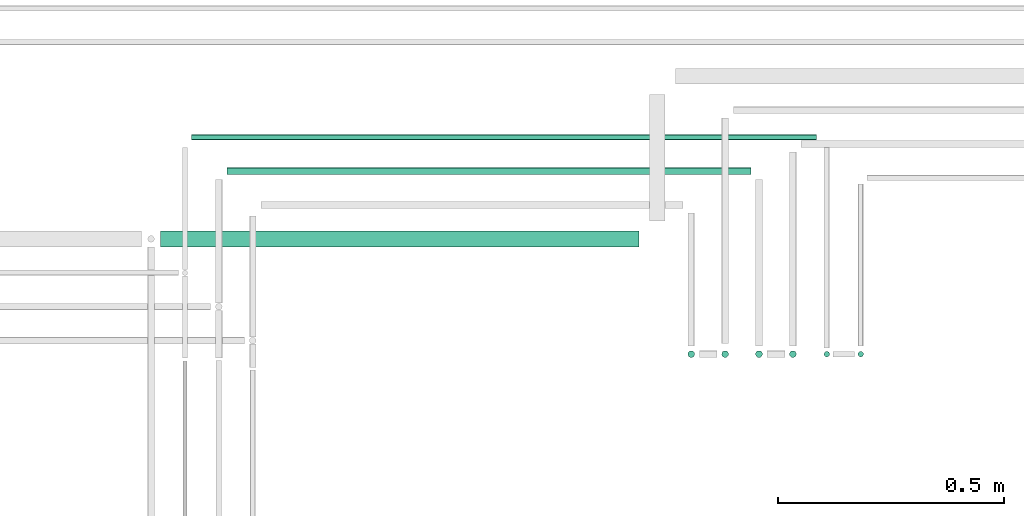
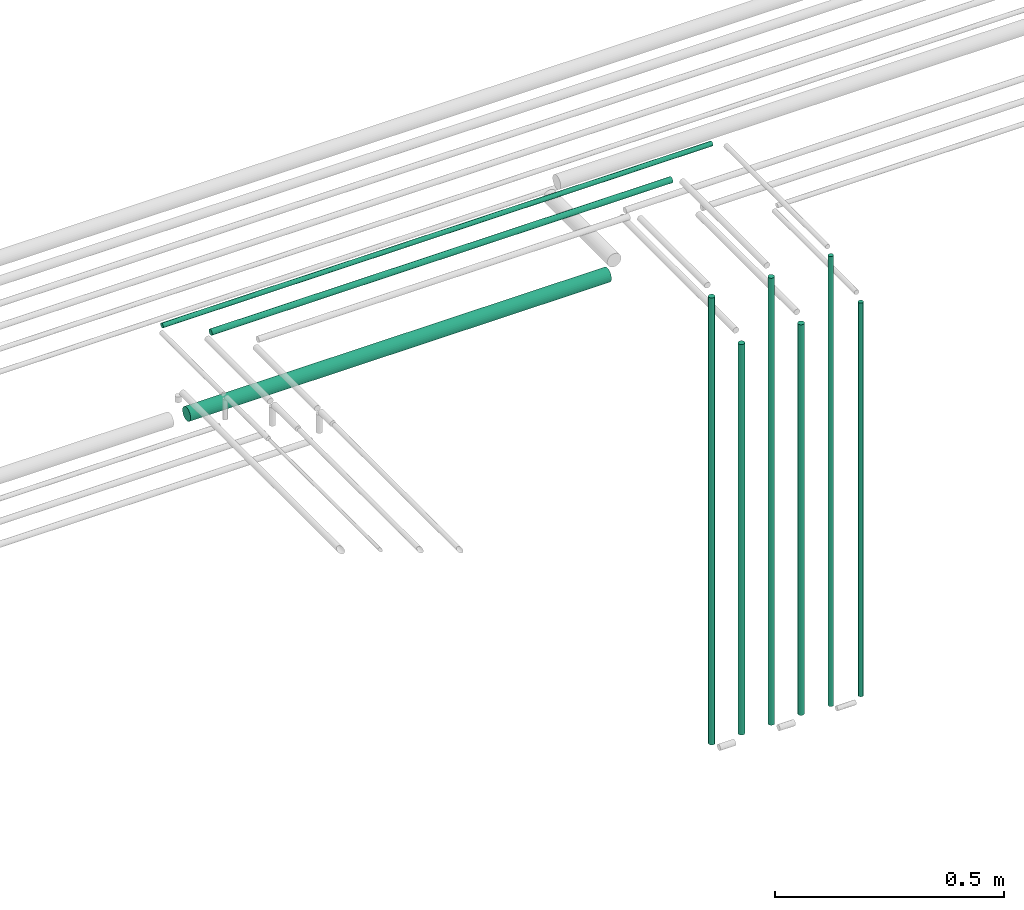
# One storey, part 16 of 65: 9 flow segments.
"""IFC2X3 building model written with IfcOpenShell, lengths in millimetres."""

from ifc_helpers import new_model, entity, si_unit, converted_unit, derived_unit, direction, frame, frame_2d, origin, origin_2d_with_axis, place, context, subcontext, project, spatial, circle, extrude, type_object, element, save


model = new_model("IFC2X3")

# Units and contexts
model_context = context("Model", 3, precision=0.01, world=origin(), true_north=direction((6.12303176911189e-17, 1.0)))
body_context = subcontext(model_context, "Body", "Model", "MODEL_VIEW")
ifc_project = project(units=[si_unit("LENGTHUNIT", "METRE", prefix="MILLI"), si_unit("AREAUNIT", "SQUARE_METRE"), si_unit("VOLUMEUNIT", "CUBIC_METRE"), converted_unit("PLANEANGLEUNIT", "DEGREE", entity("IfcRatioMeasure", 0.0174532925199433), si_unit("PLANEANGLEUNIT", "RADIAN"), dimensions=[0, 0, 0, 0, 0, 0, 0]), si_unit("MASSUNIT", "GRAM", prefix="KILO"), derived_unit("MASSDENSITYUNIT", [(si_unit("MASSUNIT", "GRAM", prefix="KILO"), 1), (si_unit("LENGTHUNIT", "METRE"), -3)]), derived_unit("MOMENTOFINERTIAUNIT", [(si_unit("LENGTHUNIT", "METRE"), 4)]), si_unit("TIMEUNIT", "SECOND"), si_unit("FREQUENCYUNIT", "HERTZ"), si_unit("THERMODYNAMICTEMPERATUREUNIT", "DEGREE_CELSIUS"), derived_unit("THERMALTRANSMITTANCEUNIT", [(si_unit("MASSUNIT", "GRAM", prefix="KILO"), 1), (si_unit("THERMODYNAMICTEMPERATUREUNIT", "KELVIN"), -1), (si_unit("TIMEUNIT", "SECOND"), -3)]), derived_unit("VOLUMETRICFLOWRATEUNIT", [(si_unit("LENGTHUNIT", "METRE"), 3), (si_unit("TIMEUNIT", "SECOND"), -1)]), derived_unit("MASSFLOWRATEUNIT", [(si_unit("MASSUNIT", "GRAM", prefix="KILO"), 1), (si_unit("TIMEUNIT", "SECOND"), -1)]), derived_unit("ROTATIONALFREQUENCYUNIT", [(si_unit("TIMEUNIT", "SECOND"), -1)]), si_unit("ELECTRICCURRENTUNIT", "AMPERE"), si_unit("ELECTRICVOLTAGEUNIT", "VOLT"), si_unit("POWERUNIT", "WATT"), si_unit("FORCEUNIT", "NEWTON", prefix="KILO"), si_unit("ILLUMINANCEUNIT", "LUX"), si_unit("LUMINOUSFLUXUNIT", "LUMEN"), si_unit("LUMINOUSINTENSITYUNIT", "CANDELA"), derived_unit("USERDEFINED", [(si_unit("MASSUNIT", "GRAM", prefix="KILO"), -1), (si_unit("LENGTHUNIT", "METRE"), -2), (si_unit("TIMEUNIT", "SECOND"), 3), (si_unit("LUMINOUSFLUXUNIT", "LUMEN"), 1)]), derived_unit("LINEARVELOCITYUNIT", [(si_unit("LENGTHUNIT", "METRE"), 1), (si_unit("TIMEUNIT", "SECOND"), -1)]), si_unit("PRESSUREUNIT", "PASCAL"), derived_unit("USERDEFINED", [(si_unit("LENGTHUNIT", "METRE"), -2), (si_unit("MASSUNIT", "GRAM", prefix="KILO"), 1), (si_unit("TIMEUNIT", "SECOND"), -2)]), derived_unit("LINEARFORCEUNIT", [(si_unit("MASSUNIT", "GRAM", prefix="KILO"), 1), (si_unit("LENGTHUNIT", "METRE"), 1), (si_unit("TIMEUNIT", "SECOND"), -2), (si_unit("LENGTHUNIT", "METRE"), -1)]), derived_unit("PLANARFORCEUNIT", [(si_unit("MASSUNIT", "GRAM", prefix="KILO"), 1), (si_unit("LENGTHUNIT", "METRE"), 1), (si_unit("TIMEUNIT", "SECOND"), -2), (si_unit("LENGTHUNIT", "METRE"), -2)])], contexts=[model_context])

# Site, building, storey
site_placement = place(None, frame((0.0, -0.00077364408347762, 0.0)))
site = spatial("IfcSite", under=ifc_project, at=site_placement, CompositionType="ELEMENT")
building_placement = place(site_placement, origin())
building = spatial("IfcBuilding", under=site, at=building_placement, CompositionType="ELEMENT")
storey_placement = place(building_placement, frame((0.0, 0.0, 19800.0)))
storey = spatial("IfcBuildingStorey", under=building, at=storey_placement, CompositionType="ELEMENT", Elevation=19800.0)

# Flow segments
pipe_segment_type = type_object("IfcPipeSegmentType", PredefinedType="NOTDEFINED")
flow_segment_1_placement = place(storey_placement, frame((61166.8052438068, 7626.05393966759, 1418.0)))
element("IfcFlowSegment", 1, at=flow_segment_1_placement, inside=storey, type_object=pipe_segment_type, context=body_context, shape_type="SweptSolid", body=[
    extrude(circle(Radius=7.5, at=frame_2d((-8.66293703438714e-12, 0.0), x_axis=(1.0, 0.0))), frame((9.09527223592286, 9.09527223591636, 0.0)), (0.0, 0.0, 1.0), 1039.00000000002),
])
flow_segment_2_placement = place(storey_placement, frame((61091.8052438068, 7626.0539396676, 1418.0)))
element("IfcFlowSegment", 2, at=flow_segment_2_placement, inside=storey, type_object=pipe_segment_type, context=body_context, shape_type="SweptSolid", body=[
    extrude(circle(Radius=7.5, at=origin_2d_with_axis()), frame((9.09527223591419, 9.09527223591636, 0.0), z_axis=(0.0, 0.0, 1.0), x_axis=(-1.0, 0.0, 0.0)), (0.0, 0.0, 1.0), 1189.0),
])
flow_segment_3_placement = place(storey_placement, frame((61316.8052438068, 7626.05393966758, 1418.0)))
element("IfcFlowSegment", 3, at=flow_segment_3_placement, inside=storey, type_object=pipe_segment_type, context=body_context, shape_type="SweptSolid", body=[
    extrude(circle(Radius=7.5, at=frame_2d((-8.66293703438714e-12, 0.0), x_axis=(1.0, 0.0))), frame((9.09527223592286, 9.09527223591636, 0.0)), (0.0, 0.0, 1.0), 1039.00000000002),
])
flow_segment_4_placement = place(storey_placement, frame((61241.8052438068, 7626.05393966759, 1418.0)))
element("IfcFlowSegment", 4, at=flow_segment_4_placement, inside=storey, type_object=pipe_segment_type, context=body_context, shape_type="SweptSolid", body=[
    extrude(circle(Radius=7.5, at=origin_2d_with_axis()), frame((9.09527223591419, 9.09527223591636, 0.0), z_axis=(0.0, 0.0, 1.0), x_axis=(-1.0, 0.0, 0.0)), (0.0, 0.0, 1.0), 1189.0),
])
flow_segment_5_placement = place(storey_placement, frame((60073.9005160427, 8030.90472776408, 2615.90472776409)))
element("IfcFlowSegment", 5, at=flow_segment_5_placement, inside=storey, type_object=pipe_segment_type, context=body_context, shape_type="SweptSolid", body=[
    extrude(circle(Radius=7.5, at=frame_2d((-1.08286712929839e-12, 0.0), x_axis=(1.0, 0.0))), frame((0.0, 9.09527223591744, 9.09527223591419), z_axis=(1.0, 0.0, 0.0), x_axis=(0.0, 1.0, 0.0)), (0.0, 0.0, 1.0), 1159.00000000001),
])
flow_segment_6_placement = place(storey_placement, frame((61468.3052438068, 7627.55393966758, 1414.0)))
element("IfcFlowSegment", 6, at=flow_segment_6_placement, inside=storey, type_object=pipe_segment_type, context=body_context, shape_type="SweptSolid", body=[
    extrude(circle(Radius=6.0, at=frame_2d((0.0, -1.08286712929839e-12), x_axis=(1.0, 0.0))), frame((7.59527223591454, 7.5952722359167, 0.0)), (0.0, 0.0, 1.0), 1047.00000000001),
])
flow_segment_7_placement = place(storey_placement, frame((61393.3052438067, 7627.55393966759, 1414.0)))
element("IfcFlowSegment", 7, at=flow_segment_7_placement, inside=storey, type_object=pipe_segment_type, context=body_context, shape_type="SweptSolid", body=[
    extrude(circle(Radius=6.0, at=origin_2d_with_axis()), frame((7.59527223591454, 7.59527223591562, 0.0), z_axis=(0.0, 0.0, 1.0), x_axis=(-1.0, 0.0, 0.0)), (0.0, 0.0, 1.0), 1197.0),
])
flow_segment_8_placement = place(storey_placement, frame((59994.9005160427, 8107.40472776408, 2617.40472776409)))
element("IfcFlowSegment", 8, at=flow_segment_8_placement, inside=storey, type_object=pipe_segment_type, context=body_context, shape_type="SweptSolid", body=[
    extrude(circle(Radius=6.0, at=origin_2d_with_axis()), frame((0.0, 7.59527223591778, 7.59527223591454), z_axis=(1.0, 0.0, 0.0), x_axis=(0.0, -1.0, 0.0)), (0.0, 0.0, 1.0), 1382.99999999999),
])
flow_segment_9_placement = place(storey_placement, frame((59926.9005160427, 7870.90472776409, 2530.90472776409)))
element("IfcFlowSegment", 9, at=flow_segment_9_placement, inside=storey, type_object=pipe_segment_type, context=body_context, shape_type="SweptSolid", body=[
    extrude(circle(Radius=17.5, at=frame_2d((1.08286712929839e-12, 0.0), x_axis=(1.0, 0.0))), frame((0.0, 19.0952722359173, 19.0952722359163), z_axis=(1.0, 0.0, 0.0), x_axis=(0.0, 1.0, 0.0)), (0.0, 0.0, 1.0), 1058.99999999997),
])

save(model, "model.ifc")
